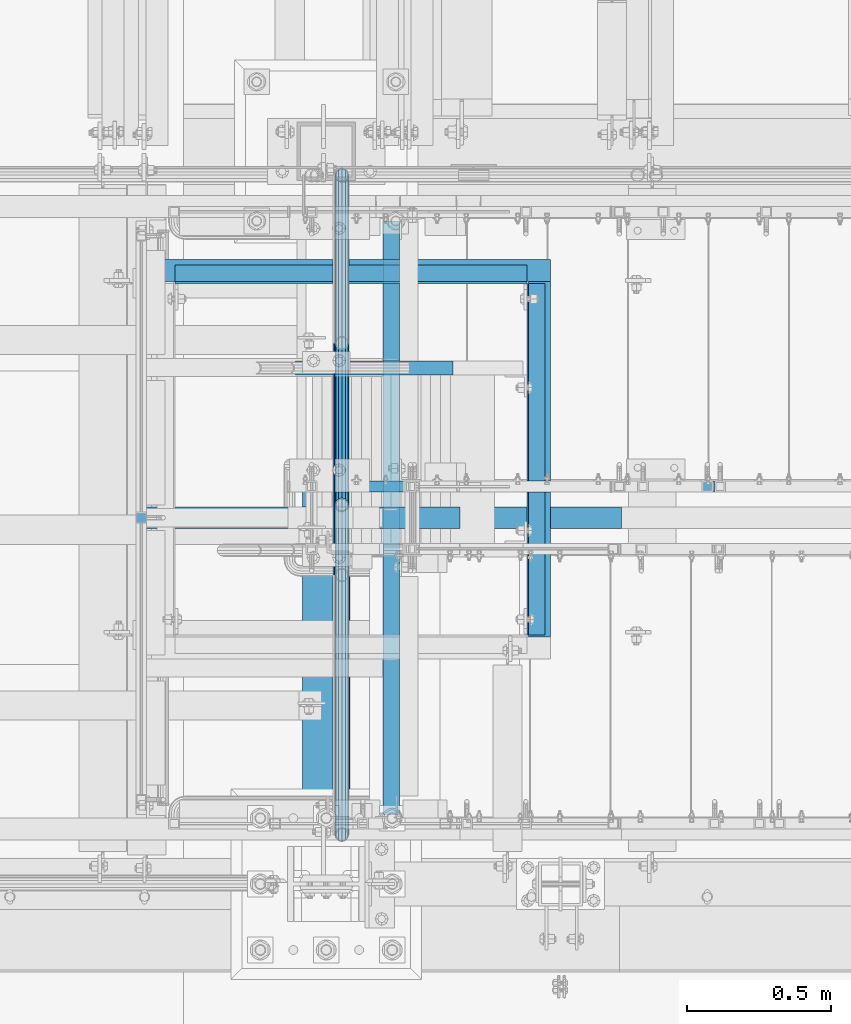
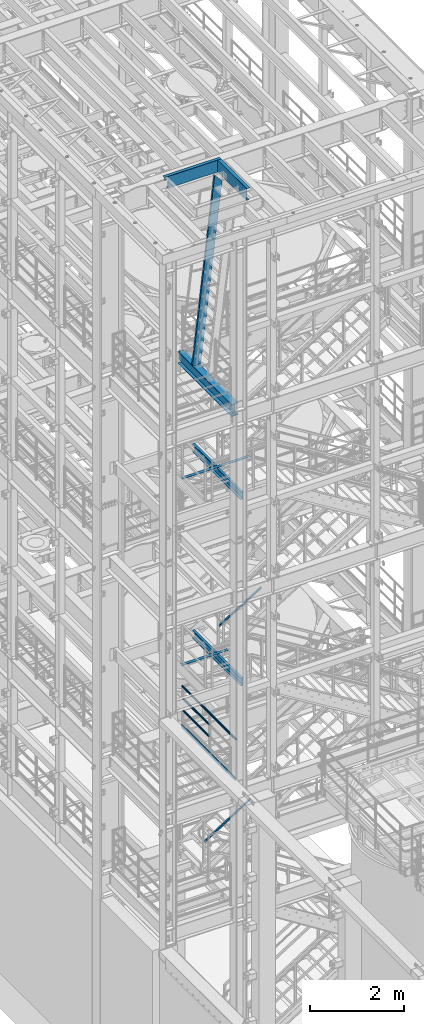
# One storey, part 965 of 1876: 13 beams, 3 members, 10 elements without a shape of their own.
"""IFC2X3 building model written with IfcOpenShell, lengths in millimetres."""

from ifc_helpers import new_model, si_unit, frame, origin_with_axes, place, context, subcontext, project, spatial, faceted_brep, material, type_object, element, aggregate, save


model = new_model("IFC2X3")

# Units and contexts
model_context = context("Model", 3, precision=1e-05, world=origin_with_axes())
body_context = subcontext(model_context, "Body", "Model", "MODEL_VIEW")
ifc_project = project(units=[si_unit("LENGTHUNIT", "METRE", prefix="MILLI"), si_unit("AREAUNIT", "SQUARE_METRE"), si_unit("VOLUMEUNIT", "CUBIC_METRE"), si_unit("MASSUNIT", "GRAM", prefix="KILO"), si_unit("TIMEUNIT", "SECOND"), si_unit("PLANEANGLEUNIT", "RADIAN"), si_unit("SOLIDANGLEUNIT", "STERADIAN"), si_unit("THERMODYNAMICTEMPERATUREUNIT", "DEGREE_CELSIUS"), si_unit("LUMINOUSINTENSITYUNIT", "LUMEN")], contexts=[model_context])

# Site, building, storey
site_placement = place(None, origin_with_axes())
site = spatial("IfcSite", under=ifc_project, at=site_placement, CompositionType="ELEMENT")
building_placement = place(site_placement, origin_with_axes())
building = spatial("IfcBuilding", under=site, at=building_placement, Name="Undefined", CompositionType="ELEMENT")
storey_placement = place(building_placement, origin_with_axes())
storey = spatial("IfcBuildingStorey", under=building, at=storey_placement, Name="Undefined", CompositionType="ELEMENT", Elevation=0.0)

# Assembly, beams
assembly_1_placement = place(storey_placement, origin_with_axes())
assembly_1 = element("IfcElementAssembly", 1, at=assembly_1_placement, inside=storey, Name="RAIL", AssemblyPlace="NOTDEFINED", PredefinedType="RIGID_FRAME")
ifc_material_1 = material()
beam_type_1 = type_object("IfcBeamType", Name="PIPE1-1/2SCH40", PredefinedType="NOTDEFINED")
beam_1_placement = place(assembly_1_placement, frame((1781.17500000097, -5797.55000057277, 8620.125), z_axis=(0.0, 0.0, -1.0), x_axis=(0.0, 1.0, 0.0)))
beam_1 = element("IfcBeam", 2, at=beam_1_placement, type_object=beam_type_1, material=ifc_material_1, Name="RAIL", ObjectType="PIPE1-1/2SCH40", context=body_context, shape_type="Brep", body=[
    faceted_brep([(0.0, 24.1299999999992, 0.0), (12.0650000000064, 20.8971929933177, -12.0649999999987), (12.0650000000064, 20.8971929933177, 12.0649999999987), (12.0650000000064, -20.8971929933177, 12.0649999999987), (12.0650000000064, -20.8971929933177, -12.0649999999987), (0.0, -24.1299999999992, 0.0), (20.8971929933249, -12.0650000000005, 20.8971929933177), (20.8971929933249, -12.0650000000005, 15.8661214311796), (15.2545715621445, -17.7076214311801, 10.2235000000001), (12.5151929933249, -20.4470000000001, 0.0), (15.2545715621445, -17.7076214311801, -10.2235000000001), (20.8971929933249, -12.0650000000005, -15.8661214311796), (20.8971929933249, -12.0650000000005, -20.8971929933177), (24.1300000000063, 0.0, -20.4470000000001), (24.1300000000063, 0.0, -24.130000000001), (21.3906214311868, -10.2235000000001, -17.7076214311819), (21.3906214311868, 10.2235000000001, -17.7076214311819), (20.8971929933249, 12.0650000000005, -15.8661214311796), (20.8971929933249, 12.0650000000005, -20.8971929933177), (15.2545715621445, 17.7076214311801, -10.2235000000001), (12.5151929933249, 20.4470000000001, 0.0), (15.2545715621445, 17.7076214311801, 10.2235000000001), (20.8971929933249, 12.0650000000005, 15.8661214311796), (20.8971929933249, 12.0650000000005, 20.8971929933177), (21.3906214311868, 10.2235000000001, 17.7076214311819), (24.1300000000064, 0.0, 20.4470000000001), (24.1300000000064, 0.0, 24.130000000001), (21.3906214311868, -10.2235000000001, 17.7076214311819), (1142.99999942723, 24.1300000000001, 0.0), (1130.93499942724, 20.8971929933184, -12.0650000000005), (1122.10280643392, 12.0650000000001, -20.8971929933177), (1142.99999942724, -24.1300000010112, 0.0), (1130.93499942724, -20.8971929933184, -12.0650000000005), (1130.93499942724, -20.8971929933184, 12.0650000000005), (1122.10280643392, -12.0650000000001, 20.8971929933177), (1122.10280643392, -12.0650000000001, -20.8971929933177), (1118.86999942724, 0.0, -24.1299999999992), (1121.60937799633, 10.2235000000001, -17.7076214311801), (1118.86999942724, 0.0, -20.4470000000001), (1122.10280643392, 12.0649999989889, -15.866121432191), (1122.10280643392, -12.0650000010112, -15.8661214301701), (1121.60937799578, -10.2235000000001, -17.7076214311801), (1127.74542786409, -17.7076214311803, -10.2235000000001), (1130.48480643291, -20.4469999999999, 0.0), (1127.74542786409, -17.7076214311803, 10.2235000000001), (1122.10280643392, -12.0650000010112, 15.8661214301701), (1121.60937799578, -10.2235000000001, 17.7076214311801), (1118.86999942724, -2.11457518162206e-11, 20.4470000000001), (1118.86999942724, -2.11457518162206e-11, 24.1299999999992), (1122.10280643392, 12.0650000000001, 20.8971929933177), (1130.93499942724, 20.8971929933184, 12.0650000000005), (1122.10280643392, 12.0649999989889, 15.866121432191), (1127.74542786611, 17.7076214311803, 10.2235000000001), (1130.48480643493, 20.4469999999999, 0.0), (1127.74542786611, 17.7076214311803, -10.2235000000001), (1121.60937799633, 10.2235000000001, 17.7076214311801)], [[[0, 1, 2]], [[3, 4, 5]], [[6, 7, 8, 9, 10, 11, 12, 4, 3]], [[13, 14, 12, 11, 15]], [[16, 17, 18, 14, 13]], [[2, 1, 18, 17, 19, 20, 21, 22, 23]], [[23, 22, 24, 25, 26]], [[26, 25, 27, 7, 6]], [[1, 0, 28, 29]], [[18, 1, 29, 30]], [[31, 32, 33]], [[6, 3, 33, 34]], [[3, 5, 31, 33]], [[5, 4, 32, 31]], [[4, 12, 35, 32]], [[12, 14, 36, 35]], [[14, 18, 30, 36]], [[37, 38, 36, 30, 39]], [[40, 35, 36, 38, 41]], [[33, 32, 35, 40, 42, 43, 44, 45, 34]], [[34, 45, 46, 47, 48]], [[26, 6, 34, 48]], [[2, 23, 49, 50]], [[23, 26, 48, 49]], [[0, 2, 50, 28]], [[28, 50, 29]], [[49, 51, 52, 53, 54, 39, 30, 29, 50]], [[48, 47, 55, 51, 49]], [[25, 24, 55, 47]], [[55, 24, 22, 21, 52, 51]], [[21, 20, 53, 52]], [[20, 19, 54, 53]], [[19, 17, 16, 37, 39, 54]], [[16, 13, 38, 37]], [[13, 15, 41, 38]], [[41, 15, 11, 10, 42, 40]], [[10, 9, 43, 42]], [[9, 8, 44, 43]], [[8, 7, 27, 46, 45, 44]], [[27, 25, 47, 46]]]),
])
beam_2_placement = place(assembly_1_placement, frame((1781.17500000097, -5797.55000057277, 8924.925), z_axis=(0.0, 0.0, -1.0), x_axis=(0.0, 1.0, 0.0)))
beam_2 = element("IfcBeam", 3, at=beam_2_placement, type_object=beam_type_1, material=ifc_material_1, Name="RAIL", ObjectType="PIPE1-1/2SCH40", context=body_context, shape_type="Brep", body=[
    faceted_brep([(0.0, 24.1299999999992, 0.0), (12.0650000000064, 20.8971929933177, -12.0649999999987), (12.0650000000064, 20.8971929933177, 12.0649999999987), (12.0650000000064, -20.8971929933177, 12.0649999999987), (12.0650000000064, -20.8971929933177, -12.0649999999987), (0.0, -24.1299999999992, 0.0), (20.8971929933249, -12.0650000000005, 20.8971929933177), (20.8971929933249, -12.0650000000005, 15.8661214311796), (15.2545715621445, -17.7076214311801, 10.2235000000001), (12.5151929933249, -20.4470000000001, 0.0), (15.2545715621445, -17.7076214311801, -10.2235000000001), (20.8971929933249, -12.0650000000005, -15.8661214311796), (20.8971929933249, -12.0650000000005, -20.8971929933177), (24.1300000000063, 0.0, -20.4470000000001), (24.1300000000063, 0.0, -24.130000000001), (21.3906214311868, -10.2235000000001, -17.7076214311819), (21.3906214311868, 10.2235000000001, -17.7076214311819), (20.8971929933249, 12.0650000000005, -15.8661214311796), (20.8971929933249, 12.0650000000005, -20.8971929933177), (15.2545715621445, 17.7076214311801, -10.2235000000001), (12.5151929933249, 20.4470000000001, 0.0), (15.2545715621445, 17.7076214311801, 10.2235000000001), (20.8971929933249, 12.0650000000005, 15.8661214311796), (20.8971929933249, 12.0650000000005, 20.8971929933177), (21.3906214311868, 10.2235000000001, 17.7076214311819), (24.1300000000064, 0.0, 20.4470000000001), (24.1300000000064, 0.0, 24.130000000001), (21.3906214311868, -10.2235000000001, 17.7076214311819), (1142.99999942723, 24.1300000000001, 0.0), (1130.93499942724, 20.8971929933184, -12.0650000000005), (1122.10280643392, 12.0650000000001, -20.8971929933177), (1142.99999942724, -24.1300000010112, 0.0), (1130.93499942724, -20.8971929933184, -12.0650000000005), (1130.93499942724, -20.8971929933184, 12.0650000000005), (1122.10280643392, -12.0650000000001, 20.8971929933177), (1122.10280643392, -12.0650000000001, -20.8971929933177), (1118.86999942724, 0.0, -24.1299999999992), (1121.60937799633, 10.2235000000001, -17.7076214311801), (1118.86999942724, 0.0, -20.4470000000001), (1122.10280643392, 12.0649999989889, -15.866121432191), (1122.10280643392, -12.0650000010112, -15.8661214301701), (1121.60937799578, -10.2235000000001, -17.7076214311801), (1127.74542786409, -17.7076214311803, -10.2235000000001), (1130.48480643291, -20.4469999999999, 0.0), (1127.74542786409, -17.7076214311803, 10.2235000000001), (1122.10280643392, -12.0650000010112, 15.8661214301701), (1121.60937799578, -10.2235000000001, 17.7076214311801), (1118.86999942724, -2.11457518162206e-11, 20.4470000000001), (1118.86999942724, -2.11457518162206e-11, 24.1299999999992), (1122.10280643392, 12.0650000000001, 20.8971929933177), (1130.93499942724, 20.8971929933184, 12.0650000000005), (1122.10280643392, 12.0649999989889, 15.866121432191), (1127.74542786611, 17.7076214311803, 10.2235000000001), (1130.48480643493, 20.4469999999999, 0.0), (1127.74542786611, 17.7076214311803, -10.2235000000001), (1121.60937799633, 10.2235000000001, 17.7076214311801)], [[[0, 1, 2]], [[3, 4, 5]], [[6, 7, 8, 9, 10, 11, 12, 4, 3]], [[13, 14, 12, 11, 15]], [[16, 17, 18, 14, 13]], [[2, 1, 18, 17, 19, 20, 21, 22, 23]], [[23, 22, 24, 25, 26]], [[26, 25, 27, 7, 6]], [[1, 0, 28, 29]], [[18, 1, 29, 30]], [[31, 32, 33]], [[6, 3, 33, 34]], [[3, 5, 31, 33]], [[5, 4, 32, 31]], [[4, 12, 35, 32]], [[12, 14, 36, 35]], [[14, 18, 30, 36]], [[37, 38, 36, 30, 39]], [[40, 35, 36, 38, 41]], [[33, 32, 35, 40, 42, 43, 44, 45, 34]], [[34, 45, 46, 47, 48]], [[26, 6, 34, 48]], [[2, 23, 49, 50]], [[23, 26, 48, 49]], [[0, 2, 50, 28]], [[28, 50, 29]], [[49, 51, 52, 53, 54, 39, 30, 29, 50]], [[48, 47, 55, 51, 49]], [[25, 24, 55, 47]], [[55, 24, 22, 21, 52, 51]], [[21, 20, 53, 52]], [[20, 19, 54, 53]], [[19, 17, 16, 37, 39, 54]], [[16, 13, 38, 37]], [[13, 15, 41, 38]], [[41, 15, 11, 10, 42, 40]], [[10, 9, 43, 42]], [[9, 8, 44, 43]], [[8, 7, 27, 46, 45, 44]], [[27, 25, 47, 46]]]),
])
beam_3_placement = place(assembly_1_placement, frame((1781.17499999996, -6964.68, 9229.725), z_axis=(0.0, 0.0, -1.0), x_axis=(0.0, 1.0, 0.0)))
beam_3 = element("IfcBeam", 4, at=beam_3_placement, type_object=beam_type_1, material=ifc_material_1, Name="RAIL", ObjectType="PIPE1-1/2SCH40", context=body_context, shape_type="Brep", body=[
    faceted_brep([(24.1300000000001, -20.4469999999999, 0.0), (34.3535000000002, -17.7076214311803, 10.2235000000001), (2299.90649885446, -17.7076214311803, 10.2235000000001), (2310.12999885446, -20.4469999999999, 0.0), (41.8376214311802, -10.2235000000001, 17.7076214311819), (2292.42237742328, -10.2235000000001, 17.7076214311801), (44.5770000000002, 0.0, 20.4470000000001), (2289.68299885446, 0.0, 20.4470000000001), (41.8376214311802, 10.2235000000001, 17.7076214311819), (2292.42237742328, 10.2235000000001, 17.7076214311801), (34.3535000000002, 17.7076214311803, 10.2235000000001), (2299.90649885446, 17.7076214311803, 10.2235000000001), (24.1300000000001, 20.4469999999999, 0.0), (2310.12999885446, 20.4469999999999, 0.0), (13.9065000000001, 17.7076214311803, -10.2235000000001), (2320.35349885446, 17.7076214311803, -10.2235000000001), (6.42237856882002, 10.2235000000001, -17.7076214311819), (2327.83762028564, 10.2235000000001, -17.7076214311801), (3.68299999999999, 0.0, -20.4470000000001), (2330.57699885446, 0.0, -20.4470000000001), (6.42237856882002, -10.2235000000001, -17.7076214311819), (2327.83762028564, -10.2235000000001, -17.7076214311801), (13.9065000000001, -17.7076214311803, -10.2235000000001), (2320.35349885446, -17.7076214311803, -10.2235000000001), (24.1299999999854, -24.1299999999992, 0.0), (12.0650000000064, -20.8971929933177, -12.0649999999987), (2322.19499885446, -20.8971929933184, -12.0650000000005), (2310.12999885446, -24.1300000000001, 0.0), (3.23280700668147, -12.0650000000001, -20.8971929933177), (2331.02719184778, -12.0650000000001, -20.8971929933177), (-1.45519152283669e-11, 0.0, -24.130000000001), (2334.25999885446, 0.0, -24.1299999999992), (3.23280700668147, 12.0650000000001, -20.8971929933177), (2331.02719184778, 12.0650000000001, -20.8971929933177), (12.0650000000064, 20.8971929933177, -12.0649999999987), (2322.19499885446, 20.8971929933184, -12.0650000000005), (24.1300000000047, 24.1299999999992, 0.0), (2310.12999885446, 24.1300000000001, 0.0), (36.1949999999997, 20.8971929933184, 12.0649999999987), (2298.06499885446, 20.8971929933184, 12.0650000000005), (45.0271929933187, 12.0650000000001, 20.8971929933177), (2289.23280586114, 12.0650000000001, 20.8971929933177), (48.2600000000002, 0.0, 24.130000000001), (2285.99999885446, 0.0, 24.1299999999992), (45.0271929933187, -12.0650000000001, 20.8971929933177), (2289.23280586114, -12.0650000000001, 20.8971929933177), (36.1949999999997, -20.8971929933184, 12.0649999999987), (2298.06499885446, -20.8971929933184, 12.0650000000005)], [[[0, 1, 2, 3]], [[1, 4, 5, 2]], [[4, 6, 7, 5]], [[6, 8, 9, 7]], [[8, 10, 11, 9]], [[10, 12, 13, 11]], [[12, 14, 15, 13]], [[14, 16, 17, 15]], [[16, 18, 19, 17]], [[18, 20, 21, 19]], [[20, 22, 23, 21]], [[22, 0, 3, 23]], [[24, 25, 26, 27]], [[25, 28, 29, 26]], [[28, 30, 31, 29]], [[30, 32, 33, 31]], [[32, 34, 35, 33]], [[34, 36, 37, 35]], [[36, 38, 39, 37]], [[38, 40, 41, 39]], [[40, 42, 43, 41]], [[42, 44, 45, 43]], [[44, 46, 47, 45]], [[46, 24, 27, 47]], [[29, 31, 33, 35, 37, 39, 41, 43, 45, 47, 27, 26], [5, 7, 9, 11, 13, 15, 17, 19, 21, 23, 3, 2]], [[46, 44, 42, 40, 38, 36, 34, 32, 30, 28, 25, 24], [22, 20, 18, 16, 14, 12, 10, 8, 6, 4, 1, 0]]]),
])
ifc_material_2 = material(Name="STEEL/A36")
beam_type_2 = type_object("IfcBeamType", PredefinedType="NOTDEFINED")
beam_4_placement = place(assembly_1_placement, frame((1754.1875, -4654.55000114555, 8220.07499999999), z_axis=(0.0, 0.0, 1.0), x_axis=(0.0, -1.0, 0.0)))
beam_4 = element("IfcBeam", 5, at=beam_4_placement, type_object=beam_type_2, material=ifc_material_2, Name="PLATE", context=body_context, shape_type="Brep", body=[
    faceted_brep([(0.0, 3.17500000000018, -50.8000000000002), (0.0, 3.17500000000018, 50.8000000000002), (2285.99999885446, 3.17499999999995, 50.7999999999993), (2285.99999885446, 3.17499999999995, -50.8000000000002), (0.0, -3.17500000000018, 50.8000000000002), (2285.99999885446, -3.17499999999995, 50.7999999999993), (0.0, -3.17500000000018, -50.8000000000002), (2285.99999885446, -3.17499999999995, -50.8000000000002)], [[[0, 1, 2, 3]], [[1, 4, 5, 2]], [[4, 6, 7, 5]], [[6, 0, 3, 7]], [[5, 7, 3, 2]], [[6, 4, 1, 0]]]),
])
aggregate(assembly_1, [beam_1, beam_2, beam_3, beam_4])

# Assembly, beam
assembly_2_placement = place(storey_placement, origin_with_axes())
assembly_2 = element("IfcElementAssembly", 6, at=assembly_2_placement, inside=storey, Name="STRINGER", AssemblyPlace="NOTDEFINED", PredefinedType="RIGID_FRAME")
beam_type_3 = type_object("IfcBeamType", Name="C8X11.5", PredefinedType="NOTDEFINED")
beam_5_placement = place(assembly_2_placement, frame((1952.625, -4762.50000114587, 15461.4867791615), z_axis=(0.0, 0.0, 1.0), x_axis=(0.0, -1.0, 0.0)))
beam_5 = element("IfcBeam", 7, at=beam_5_placement, type_object=beam_type_3, material=ifc_material_2, Name="STRINGER", ObjectType="C8X11.5", context=body_context, shape_type="Brep", body=[
    faceted_brep([(50.7999999994518, 28.575, -101.6), (50.7999999994518, 28.575, 101.6), (2108.19999999805, 28.575, 101.6), (2108.19999999805, 28.575, -101.6), (50.7999999994518, -28.575, 101.6), (2108.19999999805, -28.575, 101.6), (50.7999999994518, -28.575, 96.8355950000005), (2108.19999999805, -28.575, 96.8355950000005), (50.7999999994518, 22.2249999999999, 88.3723150000005), (2108.19999999805, 22.2249999999999, 88.3723150000005), (50.7999999994518, 22.2249999999999, -88.3723150000005), (2108.19999999805, 22.2249999999999, -88.3723150000005), (50.7999999994518, -28.575, -96.8355950000005), (2108.19999999805, -28.575, -96.8355950000005), (50.7999999994518, -28.575, -101.6), (2108.19999999805, -28.575, -101.6)], [[[0, 1, 2, 3]], [[1, 4, 5, 2]], [[4, 6, 7, 5]], [[6, 8, 9, 7]], [[8, 10, 11, 9]], [[10, 12, 13, 11]], [[12, 14, 15, 13]], [[14, 0, 3, 15]], [[5, 7, 9, 11, 13, 15, 3, 2]], [[14, 12, 10, 8, 6, 4, 1, 0]]]),
])
aggregate(assembly_2, [beam_5])

assembly_3_placement = place(storey_placement, origin_with_axes())
assembly_3 = element("IfcElementAssembly", 8, at=assembly_3_placement, inside=storey, Name="STRINGER", AssemblyPlace="NOTDEFINED", PredefinedType="RIGID_FRAME")
beam_6_placement = place(assembly_3_placement, frame((1952.62500034225, -4762.50000114536, 10633.075), z_axis=(0.0, 0.0, 1.0), x_axis=(0.0, -1.0, 0.0)))
beam_6 = element("IfcBeam", 9, at=beam_6_placement, type_object=beam_type_3, material=ifc_material_2, Name="STRINGER", ObjectType="C8X11.5", context=body_context, shape_type="Brep", body=[
    faceted_brep([(50.7999999994518, 28.575, -101.6), (50.7999999994518, 28.575, 101.6), (2108.19999999805, 28.575, 101.6), (2108.19999999805, 28.575, -101.6), (50.7999999994518, -28.575, 101.6), (2108.19999999805, -28.575, 101.6), (50.7999999994518, -28.575, 96.8355950000005), (2108.19999999805, -28.575, 96.8355950000005), (50.7999999994518, 22.2249999999999, 88.3723150000005), (2108.19999999805, 22.2249999999999, 88.3723150000005), (50.7999999994518, 22.2249999999999, -88.3723150000005), (2108.19999999805, 22.2249999999999, -88.3723150000005), (50.7999999994518, -28.575, -96.8355950000005), (2108.19999999805, -28.575, -96.8355950000005), (50.7999999994518, -28.575, -101.6), (2108.19999999805, -28.575, -101.6)], [[[0, 1, 2, 3]], [[1, 4, 5, 2]], [[4, 6, 7, 5]], [[6, 8, 9, 7]], [[8, 10, 11, 9]], [[10, 12, 13, 11]], [[12, 14, 15, 13]], [[14, 0, 3, 15]], [[5, 7, 9, 11, 13, 15, 3, 2]], [[14, 12, 10, 8, 6, 4, 1, 0]]]),
])
aggregate(assembly_3, [beam_6])

# Assembly, member
assembly_4_placement = place(storey_placement, origin_with_axes())
assembly_4 = element("IfcElementAssembly", 10, at=assembly_4_placement, inside=storey, Name="RAIL", AssemblyPlace="NOTDEFINED", PredefinedType="RIGID_FRAME")
ifc_material_3 = material()
member_type_1 = type_object("IfcMemberType", Name="HSS1-1/2X1-1/2X1/8", PredefinedType="NOTDEFINED")
member_1_placement = place(assembly_4_placement, frame((1676.40000022751, -5734.05000114554, 5883.85227266263), z_axis=(-0.536875491934336, 0.0, 0.843661487896813), x_axis=(0.843661487896813, 0.0, 0.536875491934336)))
member_1 = element("IfcMember", 11, at=member_1_placement, type_object=member_type_1, material=ifc_material_3, Name="RAIL", ObjectType="HSS1-1/2X1-1/2X1/8", context=body_context, shape_type="Brep", body=[
    faceted_brep([(1351.87808442446, -19.0499992349996, 19.0499992351442), (1327.63263086906, -19.0499992349996, -19.0499992348527), (1327.63263086906, 19.0499992349996, -19.0499992348527), (1351.87808442446, 19.0499992349996, 19.0499992351442), (1349.85762991092, -15.8749992829999, 15.8749992831449), (1349.85762991092, 15.8749992829999, 15.8749992831449), (1329.6530853826, 15.8749992829999, -15.8749992828534), (1329.6530853826, -15.8749992829999, -15.8749992828534), (34.7028723789208, 19.0499992349996, 19.0499992350083), (34.7028723789208, -19.0499992349996, 19.0499992350083), (10.4574188235219, -19.0499992349996, -19.0499992349946), (10.4574188235219, 19.0499992349996, -19.0499992349946), (32.6824178653787, 15.8749992829999, 15.8749992830085), (32.6824178653787, -15.8749992829999, 15.8749992830085), (12.4778733370622, -15.8749992829999, -15.8749992829939), (12.4778733370622, 15.8749992829999, -15.8749992829939)], [[[0, 1, 2, 3], [4, 5, 6, 7]], [[0, 3, 8, 9]], [[2, 1, 10, 11]], [[1, 0, 9, 10]], [[3, 2, 11, 8]], [[10, 9, 8, 11], [12, 13, 14, 15]], [[4, 7, 14, 13]], [[7, 6, 15, 14]], [[6, 5, 12, 15]], [[5, 4, 13, 12]]]),
])
aggregate(assembly_4, [member_1])

assembly_5_placement = place(storey_placement, origin_with_axes())
assembly_5 = element("IfcElementAssembly", 12, at=assembly_5_placement, inside=storey, Name="RAIL", AssemblyPlace="NOTDEFINED", PredefinedType="RIGID_FRAME")
member_2_placement = place(assembly_5_placement, frame((2032.00000034788, -5734.05000114554, 11352.5492418123), z_axis=(-0.523953411146183, 0.0, 0.851746924237639), x_axis=(0.851746924237639, 0.0, 0.523953411146184)))
member_2 = element("IfcMember", 13, at=member_2_placement, type_object=member_type_1, material=ifc_material_3, Name="RAIL", ObjectType="HSS1-1/2X1-1/2X1/8", context=body_context, shape_type="Brep", body=[
    faceted_brep([(1234.38228196586, -19.0499992349996, 19.0499992361129), (1210.94501017189, -19.0499992349996, -19.0499992339264), (1210.94501017189, 19.0499992349996, -19.0499992339264), (1234.38228196586, 19.0499992349996, 19.0499992361129), (1232.42917593412, -15.8749992829999, 15.8749992841094), (1232.42917593412, 15.8749992829999, 15.8749992841094), (1212.89811620362, 15.8749992829999, -15.874999281923), (1212.89811620362, -15.8749992829999, -15.874999281923), (34.0844334038557, 19.0499992349996, 19.0499992349978), (34.0844334038557, -19.0499992349996, 19.0499992349978), (10.6471616099025, -19.0499992349996, -19.0499992350033), (10.6471616099025, 19.0499992349996, -19.0499992350033), (32.1313273721225, 15.8749992829999, 15.874999282998), (32.1313273721225, -15.8749992829999, 15.874999282998), (12.6002676416374, -15.8749992829999, -15.8749992830035), (12.6002676416374, 15.8749992829999, -15.8749992830035)], [[[0, 1, 2, 3], [4, 5, 6, 7]], [[8, 9, 0, 3]], [[10, 11, 2, 1]], [[9, 10, 1, 0]], [[11, 8, 3, 2]], [[10, 9, 8, 11], [12, 13, 14, 15]], [[14, 13, 4, 7]], [[15, 14, 7, 6]], [[12, 15, 6, 5]], [[13, 12, 5, 4]]]),
])
aggregate(assembly_5, [member_2])

# Assembly, beam
assembly_6_placement = place(storey_placement, origin_with_axes())
assembly_6 = element("IfcElementAssembly", 14, at=assembly_6_placement, inside=storey, Name="ref.", AssemblyPlace="NOTDEFINED", PredefinedType="RIGID_FRAME")
ifc_material_4 = material(Name="STEEL/Steel_Undefined")
beam_type_4 = type_object("IfcBeamType", PredefinedType="NOTDEFINED")
beam_7_placement = place(assembly_6_placement, frame((2750.43044411577, -5842.00000114554, 15591.6018500827), z_axis=(0.0, 1.0, 0.0), x_axis=(-1.0, 0.0, 0.0)))
beam_7 = element("IfcBeam", 15, at=beam_7_placement, type_object=beam_type_4, material=ifc_material_4, Name="ref.", context=body_context, shape_type="Brep", body=[
    faceted_brep([(0.0, 3.17500000000018, -38.1000000000004), (0.0, 3.17500000000018, 38.1000000000004), (1683.63028047841, 3.17500000074688, 38.1000000000004), (1683.63028047841, 3.17500000074688, -38.1000000000004), (0.0, -3.17500000000018, 38.1000000000004), (1683.63028047841, -3.17499999925349, 38.1000000000004), (0.0, -3.17500000000018, -38.1000000000004), (1683.63028047841, -3.17499999925349, -38.1000000000004)], [[[0, 1, 2, 3]], [[1, 4, 5, 2]], [[4, 6, 7, 5]], [[6, 0, 3, 7]], [[5, 7, 3, 2]], [[6, 4, 1, 0]]]),
])
aggregate(assembly_6, [beam_7])

assembly_7_placement = place(storey_placement, origin_with_axes())
assembly_7 = element("IfcElementAssembly", 16, at=assembly_7_placement, inside=storey, Name="ref.", AssemblyPlace="NOTDEFINED", PredefinedType="RIGID_FRAME")
beam_8_placement = place(assembly_7_placement, frame((2191.60955085364, -5842.00000114094, 10763.2499989601), z_axis=(0.0, 1.0, 0.0), x_axis=(-1.0, 0.0, 0.0)))
beam_8 = element("IfcBeam", 17, at=beam_8_placement, type_object=beam_type_4, material=ifc_material_4, Name="ref.", context=body_context, shape_type="Brep", body=[
    faceted_brep([(0.0, 3.17500000000018, -38.1000000000004), (0.0, 3.17500000000018, 38.1000000000004), (1124.78695258368, 3.17499999999927, 38.1000000000004), (1124.78695258368, 3.17499999999927, -38.1000000000004), (0.0, -3.17500000000018, 38.1000000000004), (1124.78695258368, -3.17499999999927, 38.1000000000004), (0.0, -3.17500000000018, -38.1000000000004), (1124.78695258368, -3.17499999999927, -38.1000000000004)], [[[0, 1, 2, 3]], [[1, 4, 5, 2]], [[4, 6, 7, 5]], [[6, 0, 3, 7]], [[5, 7, 3, 2]], [[6, 4, 1, 0]]]),
])
aggregate(assembly_7, [beam_8])

# Assembly, beams
assembly_8_placement = place(storey_placement, origin_with_axes())
assembly_8 = element("IfcElementAssembly", 18, at=assembly_8_placement, inside=storey, Name="BENT_PLATE", AssemblyPlace="NOTDEFINED", PredefinedType="RIGID_FRAME")
beam_type_5 = type_object("IfcBeamType", Name="L3X3X1/4", PredefinedType="NOTDEFINED")
beam_9_placement = place(assembly_8_placement, frame((2505.075, -4984.75000152588, 22831.424987793), z_axis=(0.0, 1.0, 0.0), x_axis=(-1.0, 0.0, 0.0)))
beam_9 = element("IfcBeam", 19, at=beam_9_placement, type_object=beam_type_5, material=ifc_material_2, Name="ANGLE", ObjectType="L3X3X1/4", context=body_context, shape_type="Brep", body=[
    faceted_brep([(0.0, 38.1000000000004, -38.1), (0.0, 38.1000000000004, 38.1), (1384.3, 38.0999999999985, 38.1000000000004), (1384.3, 38.0999999999985, -38.1000000000004), (0.0, 31.75, 38.1000000000004), (1384.3, 31.75, 38.1000000000004), (0.0, 31.75, -31.75), (1384.3, 31.75, -31.75), (0.0, -38.1000000000004, -31.75), (1384.3, -38.0999999999985, -31.75), (0.0, -38.1000000000004, -38.1), (1384.3, -38.0999999999985, -38.1000000000004)], [[[0, 1, 2, 3]], [[1, 4, 5, 2]], [[4, 6, 7, 5]], [[6, 8, 9, 7]], [[8, 10, 11, 9]], [[10, 0, 3, 11]], [[5, 7, 9, 11, 3, 2]], [[10, 8, 6, 4, 1, 0]]]),
])
beam_10_placement = place(assembly_8_placement, frame((2466.97499847412, -6254.75, 22831.424987793), z_axis=(1.0, 0.0, 0.0), x_axis=(0.0, 1.0, 0.0)))
beam_10 = element("IfcBeam", 20, at=beam_10_placement, type_object=beam_type_5, material=ifc_material_2, Name="ANGLE", ObjectType="L3X3X1/4", context=body_context, shape_type="Brep", body=[
    faceted_brep([(0.0, 38.1000000000004, -38.1), (0.0, 38.1000000000004, 38.1), (1231.9, 38.0999999999985, 38.0999999999999), (1231.9, 38.0999999999985, -38.0999999999999), (0.0, 31.75, 38.1000000000004), (1231.9, 31.75, 38.0999999999999), (0.0, 31.75, -31.75), (1231.9, 31.75, -31.75), (0.0, -38.1000000000004, -31.75), (1231.9, -38.0999999999985, -31.75), (0.0, -38.1000000000004, -38.1), (1231.9, -38.0999999999985, -38.0999999999999)], [[[0, 1, 2, 3]], [[1, 4, 5, 2]], [[4, 6, 7, 5]], [[6, 8, 9, 7]], [[8, 10, 11, 9]], [[10, 0, 3, 11]], [[5, 7, 9, 11, 3, 2]], [[10, 8, 6, 4, 1, 0]]]),
])

# Assembly, beam
assembly_9_placement = place(storey_placement, origin_with_axes())
assembly_9 = element("IfcElementAssembly", 21, at=assembly_9_placement, inside=storey, Name="BEAM", AssemblyPlace="NOTDEFINED", PredefinedType="RIGID_FRAME")
ifc_material_5 = material(Name="STEEL/A992")
beam_type_6 = type_object("IfcBeamType", Name="W12X30", PredefinedType="NOTDEFINED")
beam_11_placement = place(assembly_9_placement, frame((1727.2, -7112.0, 17826.0375), z_axis=(0.0, 0.0, 1.0), x_axis=(0.0, 1.0, 0.0)))
beam_11 = element("IfcBeam", 22, at=beam_11_placement, type_object=beam_type_6, material=ifc_material_5, Name="BEAM", ObjectType="W12X30", context=body_context, shape_type="Brep", body=[
    faceted_brep([(2431.25625, -3.17500000000018, -146.049999999999), (2431.25625, -82.5500000000002, -146.049999999999), (2431.25625, -82.5500000000002, -157.162499999999), (2431.25625, 82.5500000000002, -157.162499999999), (2431.25625, 82.5500000000002, -146.049999999999), (2431.25625, 3.17500000000018, -146.049999999999), (2431.25625, 3.17500000000018, -144.462499809259), (2431.25625, -3.17500000000018, -144.462499809259), (2432.22297992259, 3.17500000000018, -139.602420291212), (2432.22297992259, -3.17500000000018, -139.602420291212), (2434.97599382307, 3.17500000000018, -135.482243823059), (2434.97599382307, -3.17500000000018, -135.482243823059), (2439.09617029122, 3.17500000000018, -132.729229922581), (2439.09617029122, -3.17500000000018, -132.729229922581), (2443.95624980927, 3.17500000000018, -131.762499999993), (2443.95624980927, -3.17500000000018, -131.762499999993), (2520.15625, -3.17500000000018, -131.762499999993), (2520.15625, 3.17500000000018, -131.762499999993), (142.875, 3.17499999999995, 146.049999999999), (142.875, 82.55, 146.049999999999), (2413.79375, 82.5500000000002, 146.049999999999), (2413.79375, 3.17500000000018, 146.049999999999), (142.875, -82.55, -157.162499999999), (142.875, -82.55, -146.049999999999), (142.875, -3.17499999999995, -146.049999999999), (142.875, -3.17499999999995, 146.049999999999), (142.875, -82.55, 146.049999999999), (142.875, -82.55, 157.162499999999), (142.875, 82.55, 157.162499999999), (142.875, 3.17499999999995, -146.049999999999), (142.875, 82.55, -146.049999999999), (142.875, 82.55, -157.162499999999), (2413.79375, -3.17500000000018, 146.049999999999), (2413.79375, -82.5500000000002, 146.049999999999), (2413.79375, -82.5500000000002, 157.162499999999), (2413.79375, 82.5500000000002, 157.162499999999), (2413.79375, -3.17500000000018, 125.41249980927), (2413.79375, 3.17500000000018, 125.41249980927), (2414.76047992259, -3.17500000000018, 120.552420291224), (2414.76047992259, 3.17500000000018, 120.552420291224), (2417.51349382307, -3.17500000000018, 116.43224382307), (2417.51349382307, 3.17500000000018, 116.43224382307), (2421.63367029122, -3.17500000000018, 113.679229922593), (2421.63367029122, 3.17500000000018, 113.679229922593), (2426.49374980926, -3.17500000000018, 112.712500000005), (2426.49374980926, 3.17500000000018, 112.712500000005), (2520.15625, -3.17500000000018, 112.712500000005), (2520.15625, 3.17500000000018, 112.712500000005)], [[[0, 1, 2, 3, 4, 5, 6, 7]], [[7, 6, 8, 9]], [[9, 8, 10, 11]], [[11, 10, 12, 13]], [[13, 12, 14, 15]], [[16, 15, 14, 17]], [[18, 19, 20, 21]], [[22, 23, 24, 25, 26, 27, 28, 19, 18, 29, 30, 31]], [[26, 25, 32, 33]], [[27, 26, 33, 34]], [[28, 27, 34, 35]], [[19, 28, 35, 20]], [[34, 33, 32, 36, 37, 21, 20, 35]], [[38, 39, 37, 36]], [[40, 41, 39, 38]], [[42, 43, 41, 40]], [[44, 45, 43, 42]], [[46, 47, 45, 44]], [[47, 46, 16, 17]], [[12, 10, 8, 6, 5, 29, 18, 21, 37, 39, 41, 43, 45, 47, 17, 14]], [[30, 29, 5, 4]], [[31, 30, 4, 3]], [[22, 31, 3, 2]], [[23, 22, 2, 1]], [[24, 23, 1, 0]], [[46, 44, 42, 40, 38, 36, 32, 25, 24, 0, 7, 9, 11, 13, 15, 16]]]),
])
aggregate(assembly_9, [beam_11])

# Beam
beam_type_7 = type_object("IfcBeamType", PredefinedType="NOTDEFINED")
beam_12_placement = place(assembly_8_placement, frame((1812.925, -4965.69999999998, 22567.9), z_axis=(1.0, 0.0, 0.0), x_axis=(0.0, -1.0, 0.0)))
beam_12 = element("IfcBeam", 23, at=beam_12_placement, type_object=beam_type_7, material=ifc_material_2, Name="BENT_PLATE", context=body_context, shape_type="Brep", body=[
    faceted_brep([(0.0, -3.17499999999927, -609.6), (0.0, -3.17499999999927, 609.6), (0.0, 3.17499999999927, 609.6), (0.0, 3.17499999999927, -609.6), (63.5000000000182, 3.17499999999927, 609.6), (63.5000000000182, 3.17499999999927, -609.6), (57.1500000000178, -3.17499999999927, -609.6), (57.1500000000178, -3.17499999999927, 609.6), (63.5000000000182, -301.624987792951, 609.6), (63.5000000000182, -301.624987792951, -609.6), (57.1500000000178, -301.624987792951, 609.6), (57.1500000000178, -301.624987792951, -609.6)], [[[0, 1, 2, 3]], [[3, 2, 4, 5]], [[1, 0, 6, 7]], [[5, 4, 8, 9]], [[4, 2, 1, 7, 10, 8]], [[7, 6, 11, 10]], [[6, 0, 3, 5, 9, 11]], [[10, 11, 9, 8]]]),
])

beam_13_placement = place(assembly_8_placement, frame((2486.02500000002, -5638.8, 22567.9), z_axis=(0.0, -1.0, 0.0), x_axis=(-1.0, 0.0, 0.0)))
beam_13 = element("IfcBeam", 24, at=beam_13_placement, type_object=beam_type_7, material=ifc_material_2, Name="BENT_PLATE", context=body_context, shape_type="Brep", body=[
    faceted_brep([(0.0, -3.17499999999927, -609.6), (0.0, -3.17499999999927, 609.6), (0.0, 3.17499999999927, 609.6), (0.0, 3.17499999999927, -609.6), (63.5000000000182, 3.17499999999927, 609.6), (63.5000000000182, 3.17499999999927, -609.6), (57.1500000000178, -3.17499999999927, -609.6), (57.1500000000178, -3.17499999999927, 609.6), (63.5000000000182, -301.624987792951, 609.6), (63.5000000000182, -301.624987792951, -609.6), (57.1500000000178, -301.624987792951, 609.6), (57.1500000000178, -301.624987792951, -609.6)], [[[0, 1, 2, 3]], [[3, 2, 4, 5]], [[1, 0, 6, 7]], [[5, 4, 8, 9]], [[4, 2, 1, 7, 10, 8]], [[7, 6, 11, 10]], [[6, 0, 3, 5, 9, 11]], [[10, 11, 9, 8]]]),
])

aggregate(assembly_8, [beam_9, beam_10, beam_12, beam_13])

# Assembly, member
assembly_10_placement = place(storey_placement, origin_with_axes())
assembly_10 = element("IfcElementAssembly", 25, at=assembly_10_placement, inside=storey, Name="RIGHT STRINGER", AssemblyPlace="NOTDEFINED", PredefinedType="RIGID_FRAME")
member_type_2 = type_object("IfcMemberType", Name="MC8X8.5", PredefinedType="NOTDEFINED")
member_3_placement = place(assembly_10_placement, frame((1720.02370048873, -5322.8875, 17971.6366119602), z_axis=(0.993502247476981, 0.0, -0.113812496054638), x_axis=(0.113813257034502, 0.0, 0.993502160301224)))
member_3 = element("IfcMember", 26, at=member_3_placement, type_object=member_type_2, material=ifc_material_2, Name="LADDER", ObjectType="MC8X8.5", context=body_context, shape_type="Brep", body=[
    faceted_brep([(15.9788271959551, 23.8125, -101.60000000001), (39.2568590953379, 23.8125, 101.600000000001), (4625.18025665231, 23.8125, 101.599999999326), (4806.43121065166, 23.8125, -101.600000000716), (39.2568590953379, -23.8125, 101.600000000001), (4625.18025665231, -23.8125, 101.599999999326), (38.4018460720981, -23.8125, 94.1363687500005), (4631.83768915409, -23.8125, 94.1363687493236), (38.3041328960062, 19.0500000000002, 93.2834050000004), (4632.59851835396, 19.0500000000002, 93.2834049993235), (16.9315533952904, 19.0500000000002, -93.2834050000099), (4799.01294895, 19.0500000000002, -93.283405000714), (16.8338402192021, -23.8125, -94.1363687500099), (4799.77377814987, -23.8125, -94.1363687507136), (15.9788271959551, -23.8125, -101.60000000001), (4806.43121065166, -23.8125, -101.600000000716)], [[[0, 1, 2, 3]], [[1, 4, 5, 2]], [[4, 6, 7, 5]], [[6, 8, 9, 7]], [[8, 10, 11, 9]], [[10, 12, 13, 11]], [[12, 14, 15, 13]], [[14, 0, 3, 15]], [[5, 7, 9, 11, 13, 15, 3, 2]], [[14, 12, 10, 8, 6, 4, 1, 0]]]),
])
aggregate(assembly_10, [member_3])

save(model, "model.ifc")
